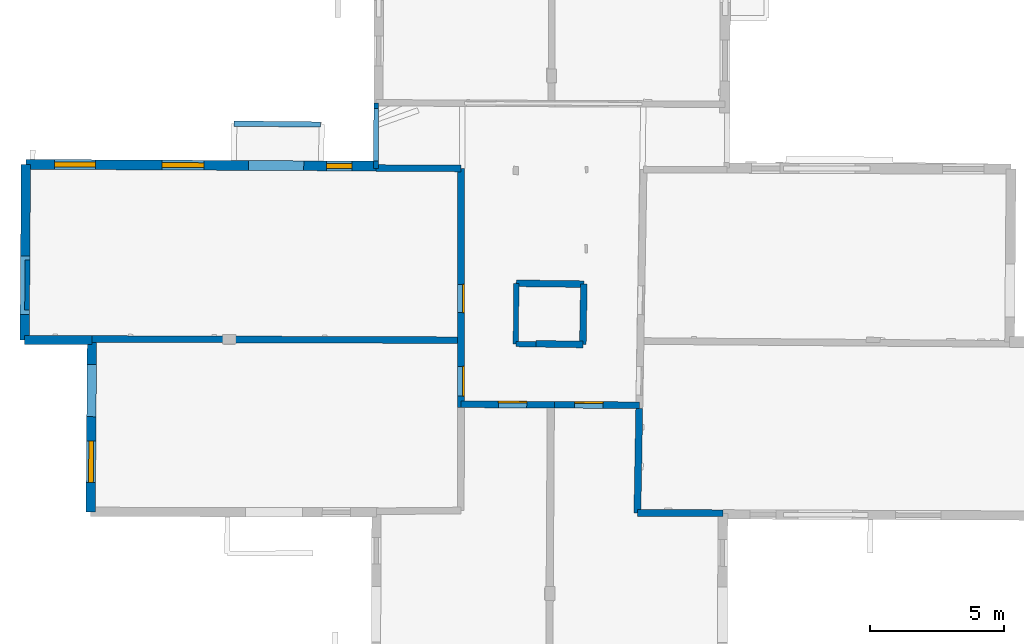
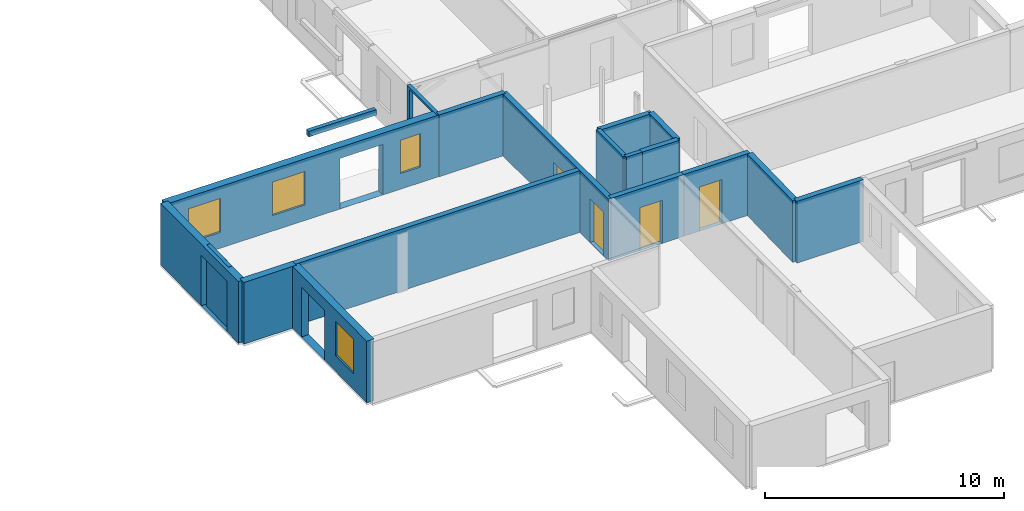
# One storey, part 3 of 14: 19 walls, 4 doors, 4 windows, 12 openings.
"""IFC2X3 building model written with IfcOpenShell, lengths in metres."""

from ifc_helpers import new_model, entity, si_unit, converted_unit, derived_unit, direction, frame, frame_2d, origin, origin_2d_with_axis, place, context, subcontext, project, spatial, polyline, rectangle, outline, extrude, source, transform, mapped, material, layer, layer_set, layer_usage, type_object, type_shapes, element, fill, save


model = new_model("IFC2X3")

# Units and contexts
model_context = context("Model", 3, precision=1e-05, world=origin(), true_north=direction((0.0, 1.0)))
body_context = subcontext(model_context, "Body", "Model", "MODEL_VIEW")
ifc_project = project(units=[si_unit("LENGTHUNIT", "METRE"), si_unit("AREAUNIT", "SQUARE_METRE"), si_unit("VOLUMEUNIT", "CUBIC_METRE"), converted_unit("PLANEANGLEUNIT", "DEGREE", entity("IfcRatioMeasure", 0.0174532925199433), si_unit("PLANEANGLEUNIT", "RADIAN"), dimensions=[0, 0, 0, 0, 0, 0, 0]), si_unit("MASSUNIT", "GRAM", prefix="KILO"), derived_unit("MASSDENSITYUNIT", [(si_unit("MASSUNIT", "GRAM", prefix="KILO"), 1), (si_unit("LENGTHUNIT", "METRE"), -3)]), derived_unit("MOMENTOFINERTIAUNIT", [(si_unit("LENGTHUNIT", "METRE"), 4)]), si_unit("TIMEUNIT", "SECOND"), si_unit("FREQUENCYUNIT", "HERTZ"), si_unit("THERMODYNAMICTEMPERATUREUNIT", "DEGREE_CELSIUS"), derived_unit("THERMALTRANSMITTANCEUNIT", [(si_unit("MASSUNIT", "GRAM", prefix="KILO"), 1), (si_unit("THERMODYNAMICTEMPERATUREUNIT", "KELVIN"), -1), (si_unit("TIMEUNIT", "SECOND"), -3)]), derived_unit("VOLUMETRICFLOWRATEUNIT", [(si_unit("LENGTHUNIT", "METRE"), 3), (si_unit("TIMEUNIT", "SECOND"), -1)]), si_unit("ELECTRICCURRENTUNIT", "AMPERE"), si_unit("ELECTRICVOLTAGEUNIT", "VOLT"), si_unit("POWERUNIT", "WATT"), si_unit("FORCEUNIT", "NEWTON", prefix="KILO"), si_unit("ILLUMINANCEUNIT", "LUX"), si_unit("LUMINOUSFLUXUNIT", "LUMEN"), si_unit("LUMINOUSINTENSITYUNIT", "CANDELA"), derived_unit("USERDEFINED", [(si_unit("MASSUNIT", "GRAM", prefix="KILO"), -1), (si_unit("LENGTHUNIT", "METRE"), -2), (si_unit("TIMEUNIT", "SECOND"), 3), (si_unit("LUMINOUSFLUXUNIT", "LUMEN"), 1)]), derived_unit("LINEARVELOCITYUNIT", [(si_unit("LENGTHUNIT", "METRE"), 1), (si_unit("TIMEUNIT", "SECOND"), -1)]), si_unit("PRESSUREUNIT", "PASCAL"), derived_unit("USERDEFINED", [(si_unit("LENGTHUNIT", "METRE"), -2), (si_unit("MASSUNIT", "GRAM", prefix="KILO"), 1), (si_unit("TIMEUNIT", "SECOND"), -2)]), derived_unit("LINEARFORCEUNIT", [(si_unit("MASSUNIT", "GRAM", prefix="KILO"), 1), (si_unit("LENGTHUNIT", "METRE"), 1), (si_unit("TIMEUNIT", "SECOND"), -2), (si_unit("LENGTHUNIT", "METRE"), -1)]), derived_unit("PLANARFORCEUNIT", [(si_unit("MASSUNIT", "GRAM", prefix="KILO"), 1), (si_unit("LENGTHUNIT", "METRE"), 1), (si_unit("TIMEUNIT", "SECOND"), -2), (si_unit("LENGTHUNIT", "METRE"), -2)])], contexts=[model_context])

# Site, building, storey
placement_1 = place(None, origin())
site = spatial("IfcSite", under=ifc_project, at=placement_1, CompositionType="ELEMENT")
building = spatial("IfcBuilding", under=site, at=placement_1, CompositionType="ELEMENT")
storey_placement = place(placement_1, frame((0.0, 0.0, 8.83152770996094)))
storey = spatial("IfcBuildingStorey", under=building, at=storey_placement, Name="Level 4", CompositionType="ELEMENT", Elevation=8.83152770996094)

# Wall
ifc_material_1 = material(Name="Default wall")
ifc_layer_1 = layer(ifc_material_1, 0.25)
ifc_layer_set_1 = layer_set([ifc_layer_1], Name="wall_thickness_0.2500")
ifc_layer_usage_1 = layer_usage(ifc_layer_set_1, "AXIS2", "POSITIVE", -0.125)
wall_type_1 = type_object("IfcWallType", Name="wall_thickness_0.2500", PredefinedType="STANDARD", material=ifc_layer_set_1)
wall_1_placement = place(storey_placement, frame((4.90263241764473, 21.567697794984, 0.0), z_axis=(0.0, 0.0, 1.0), x_axis=(0.999921550442488, -0.0125256920244768, 0.0)))
element("IfcWallStandardCase", 1, at=wall_1_placement, inside=storey, type_object=wall_type_1, material=ifc_layer_usage_1, Name="Wall:382", ObjectType="Wall", context=body_context, shape_type="SweptSolid", body=[
    extrude(outline(polyline([(2.53233176272325, -0.125), (2.53233176272325, 0.125), (0.0, 0.125), (0.0, -0.125), (2.53233176272325, -0.125)])), origin(), (0.0, 0.0, 1.0), 3.14668312072754),
])

# Wall, openings, doors
wall_2_placement = place(storey_placement, frame((2.83575512035134, 25.8687037352713, 0.0), z_axis=(0.0, 0.0, 1.0), x_axis=(-0.000411126826557853, -0.999999915487363, 0.0)))
wall_2 = element("IfcWallStandardCase", 2, at=wall_2_placement, inside=storey, type_object=wall_type_1, material=ifc_layer_usage_1, Name="Wall:383", ObjectType="Wall", context=body_context, shape_type="SweptSolid", body=[
    extrude(outline(polyline([(8.95736579302135, -0.125), (8.95736579302135, 0.125), (0.0, 0.125), (0.0, -0.125), (8.95736579302135, -0.125)])), origin(), (0.0, 0.0, 1.0), 3.14668312072754),
])
opening_1_placement = place(wall_2_placement, frame((4.34125555554509, -0.125, 0.00547218322753906)))
opening_1 = element("IfcOpeningElement", 3, at=opening_1_placement, cuts=wall_2, Name="Opening : 1055 x 2235 : 304", ObjectType="Opening", context=body_context, shape_type="SweptSolid", body=[
    extrude(rectangle(XDim=1.055, YDim=2.235, at=frame_2d((1.1175, 0.5275), x_axis=(0.0, 1.0))), frame((0.0, 0.0, 0.0), z_axis=(0.0, 1.0, 0.0), x_axis=(0.0, 0.0, 1.0)), (0.0, 0.0, 1.0), 0.25),
])
opening_2_placement = place(wall_2_placement, frame((7.41011682260127, -0.125, 0.00647258758544922)))
opening_2 = element("IfcOpeningElement", 4, at=opening_2_placement, cuts=wall_2, Name="Opening : 1120 x 2235 : 305", ObjectType="Opening", context=body_context, shape_type="SweptSolid", body=[
    extrude(rectangle(XDim=1.12, YDim=2.235, at=frame_2d((1.1175, 0.56), x_axis=(0.0, 1.0))), frame((0.0, 0.0, 0.0), z_axis=(0.0, 1.0, 0.0), x_axis=(0.0, 0.0, 1.0)), (0.0, 0.0, 1.0), 0.25),
])
ifc_material_2 = material(Name="Door Panel")
door_style_1 = type_object("IfcDoorStyle", Name="Door : 1055 x 2235mm", ConstructionType="NOTDEFINED", OperationType="SINGLE_SWING_RIGHT", ParameterTakesPrecedence=False, Sizeable=False, material=ifc_material_2)
shared_shape_1 = source(origin(), body_context, "Body", "SweptSolid", [
    extrude(rectangle(XDim=0.0625, YDim=1.055, at=origin_2d_with_axis()), frame((0.5275, 0.21875, 0.0), z_axis=(0.0, 0.0, 1.0), x_axis=(0.0, 1.0, 0.0)), (0.0, 0.0, 1.0), 2.235),
])
type_shapes(door_style_1, [shared_shape_1])
door_1_placement = place(opening_1_placement, origin())
door_1 = element("IfcDoor", 5, at=door_1_placement, inside=storey, type_object=door_style_1, Name="Door : 1055 x 2235mm : 57", ObjectType="Door : 1055 x 2235mm", OverallHeight=2.235, OverallWidth=1.055, context=body_context, shape_type="MappedRepresentation", body=[
    mapped(shared_shape_1, transform((0.0, 0.0, 0.0), scale=1.0)),
])
fill(opening_1, door_1)
door_style_2 = type_object("IfcDoorStyle", Name="Door : 1120 x 2235mm", ConstructionType="NOTDEFINED", OperationType="SINGLE_SWING_RIGHT", ParameterTakesPrecedence=False, Sizeable=False, material=ifc_material_2)
shared_shape_2 = source(origin(), body_context, "Body", "SweptSolid", [
    extrude(rectangle(XDim=0.0625, YDim=1.12, at=origin_2d_with_axis()), frame((0.56, 0.21875, 0.0), z_axis=(0.0, 0.0, 1.0), x_axis=(0.0, 1.0, 0.0)), (0.0, 0.0, 1.0), 2.235),
])
type_shapes(door_style_2, [shared_shape_2])
door_2_placement = place(opening_2_placement, origin())
door_2 = element("IfcDoor", 6, at=door_2_placement, inside=storey, type_object=door_style_2, Name="Door : 1120 x 2235mm : 58", ObjectType="Door : 1120 x 2235mm", OverallHeight=2.235, OverallWidth=1.12, context=body_context, shape_type="MappedRepresentation", body=[
    mapped(shared_shape_2, transform((0.0, 0.0, 0.0), scale=1.0)),
])
fill(opening_2, door_2)

# Wall
wall_3_placement = place(storey_placement, frame((-10.9847354461438, 19.4825045448759, 0.0), z_axis=(0.0, 0.0, 1.0), x_axis=(0.999994767675182, -0.00323490683920543, 0.0)))
element("IfcWallStandardCase", 7, at=wall_3_placement, inside=storey, type_object=wall_type_1, material=ifc_layer_usage_1, Name="Wall:387", ObjectType="Wall", context=body_context, shape_type="SweptSolid", body=[
    extrude(outline(polyline([(13.880709320427, -0.125), (13.880709320427, 0.125), (0.0, 0.125), (0.0, -0.125), (13.880709320427, -0.125)])), origin(), (0.0, 0.0, 1.0), 3.14668312072754),
])

# Wall, opening, door
wall_4_placement = place(storey_placement, frame((2.83212357896724, 17.036337199446, 0.0), z_axis=(0.0, 0.0, 1.0), x_axis=(0.999987146241394, -0.00507024180818238, 0.0)))
wall_4 = element("IfcWallStandardCase", 8, at=wall_4_placement, inside=storey, type_object=wall_type_1, material=ifc_layer_usage_1, Name="Wall:423", ObjectType="Wall", context=body_context, shape_type="SweptSolid", body=[
    extrude(outline(polyline([(3.50002472289368, -0.125), (3.50002472289368, 0.125), (0.0, 0.125), (0.0, -0.125), (3.50002472289368, -0.125)])), origin(), (0.0, 0.0, 1.0), 3.14668312072754),
])
opening_3_placement = place(wall_4_placement, frame((1.39978372506363, -0.125, 0.00647258758544922)))
opening_3 = element("IfcOpeningElement", 9, at=opening_3_placement, cuts=wall_4, Name="Opening : 1065 x 2190 : 330", ObjectType="Opening", context=body_context, shape_type="SweptSolid", body=[
    extrude(rectangle(XDim=1.065, YDim=2.19, at=frame_2d((1.095, 0.5325), x_axis=(0.0, 1.0))), frame((0.0, 0.0, 0.0), z_axis=(0.0, 1.0, 0.0), x_axis=(0.0, 0.0, 1.0)), (0.0, 0.0, 1.0), 0.25),
])
door_style_3 = type_object("IfcDoorStyle", Name="Door : 1065 x 2190mm", ConstructionType="NOTDEFINED", OperationType="SINGLE_SWING_RIGHT", ParameterTakesPrecedence=False, Sizeable=False, material=ifc_material_2)
shared_shape_3 = source(origin(), body_context, "Body", "SweptSolid", [
    extrude(rectangle(XDim=0.0625, YDim=1.065, at=origin_2d_with_axis()), frame((0.5325, 0.21875, 0.0), z_axis=(0.0, 0.0, 1.0), x_axis=(0.0, 1.0, 0.0)), (0.0, 0.0, 1.0), 2.19),
])
type_shapes(door_style_3, [shared_shape_3])
door_3_placement = place(opening_3_placement, origin())
door_3 = element("IfcDoor", 10, at=door_3_placement, inside=storey, type_object=door_style_3, Name="Door : 1065 x 2190mm : 61", ObjectType="Door : 1065 x 2190mm", OverallHeight=2.19, OverallWidth=1.065, context=body_context, shape_type="MappedRepresentation", body=[
    mapped(shared_shape_3, transform((0.0, 0.0, 0.0), scale=1.0)),
])
fill(opening_3, door_3)

wall_5_placement = place(storey_placement, frame((6.33210331338802, 17.0185912277663, 0.0), z_axis=(0.0, 0.0, 1.0), x_axis=(0.999987148651248, -0.00506976649826233, 0.0)))
wall_5 = element("IfcWallStandardCase", 11, at=wall_5_placement, inside=storey, type_object=wall_type_1, material=ifc_layer_usage_1, Name="Wall:424", ObjectType="Wall", context=body_context, shape_type="SweptSolid", body=[
    extrude(outline(polyline([(3.1798132419031, -0.125), (3.1798132419031, 0.125), (0.0, 0.125), (0.0, -0.125), (3.1798132419031, -0.125)])), origin(), (0.0, 0.0, 1.0), 3.14668312072754),
])
opening_4_placement = place(wall_5_placement, frame((0.759759601834799, -0.125, 0.00647258758544922)))
opening_4 = element("IfcOpeningElement", 12, at=opening_4_placement, cuts=wall_5, Name="Opening : 1065 x 2250 : 331", ObjectType="Opening", context=body_context, shape_type="SweptSolid", body=[
    extrude(rectangle(XDim=1.065, YDim=2.25, at=frame_2d((1.125, 0.5325), x_axis=(0.0, 1.0))), frame((0.0, 0.0, 0.0), z_axis=(0.0, 1.0, 0.0), x_axis=(0.0, 0.0, 1.0)), (0.0, 0.0, 1.0), 0.25),
])
door_style_4 = type_object("IfcDoorStyle", Name="Door : 1065 x 2250mm", ConstructionType="NOTDEFINED", OperationType="SINGLE_SWING_RIGHT", ParameterTakesPrecedence=False, Sizeable=False, material=ifc_material_2)
shared_shape_4 = source(origin(), body_context, "Body", "SweptSolid", [
    extrude(rectangle(XDim=0.0625, YDim=1.065, at=origin_2d_with_axis()), frame((0.5325, 0.21875, 0.0), z_axis=(0.0, 0.0, 1.0), x_axis=(0.0, 1.0, 0.0)), (0.0, 0.0, 1.0), 2.25),
])
type_shapes(door_style_4, [shared_shape_4])
door_4_placement = place(opening_4_placement, origin())
door_4 = element("IfcDoor", 13, at=door_4_placement, inside=storey, type_object=door_style_4, Name="Door : 1065 x 2250mm : 62", ObjectType="Door : 1065 x 2250mm", OverallHeight=2.25, OverallWidth=1.065, context=body_context, shape_type="MappedRepresentation", body=[
    mapped(shared_shape_4, transform((0.0, 0.0, 0.0), scale=1.0)),
])
fill(opening_4, door_4)

# Walls
wall_6_placement = place(storey_placement, frame((5.64531664419107, 19.303205070622, 0.0), z_axis=(0.0, 0.0, 1.0), x_axis=(0.999866020035043, -0.0163689333581485, 0.0)))
element("IfcWallStandardCase", 14, at=wall_6_placement, inside=storey, type_object=wall_type_1, material=ifc_layer_usage_1, Name="Wall:425", ObjectType="Wall", context=body_context, shape_type="SweptSolid", body=[
    extrude(outline(polyline([(1.75273107337098, -0.125), (1.75273107337098, 0.125), (0.0, 0.125), (0.0, -0.125), (1.75273107337098, -0.125)])), origin(), (0.0, 0.0, 1.0), 3.14668312072754),
])
wall_7_placement = place(storey_placement, frame((7.43476486762894, 21.5359807769144, 0.0), z_axis=(0.0, 0.0, 1.0), x_axis=(-0.0163378881642375, -0.999866527797752, 0.0)))
element("IfcWallStandardCase", 15, at=wall_7_placement, inside=storey, type_object=wall_type_1, material=ifc_layer_usage_1, Name="Wall:435", ObjectType="Wall", context=body_context, shape_type="SweptSolid", body=[
    extrude(outline(polyline([(2.26176695564838, -0.125), (2.26176695564838, 0.125), (0.0, 0.125), (0.0, -0.125), (2.26176695564838, -0.125)])), origin(), (0.0, 0.0, 1.0), 3.14668312072754),
])
wall_8_placement = place(storey_placement, frame((-0.347936725044121, 25.8836817273371, 0.0), z_axis=(0.0, 0.0, 1.0), x_axis=(0.999988930127148, -0.00470527609843498, 0.0)))
element("IfcWallStandardCase", 16, at=wall_8_placement, inside=storey, type_object=wall_type_1, material=ifc_layer_usage_1, Name="Wall:476", ObjectType="Wall", context=body_context, shape_type="SweptSolid", body=[
    extrude(outline(polyline([(3.18372734112074, -0.125), (3.18372734112074, 0.125), (0.0, 0.125), (0.0, -0.125), (3.18372734112074, -0.125)])), origin(), (0.0, 0.0, 1.0), 3.14668312072754),
])

# Wall, openings, window
ifc_layer_2 = layer(ifc_material_1, 0.349999994039536)
ifc_layer_set_2 = layer_set([ifc_layer_2], Name="wall_thickness_0.3500")
ifc_layer_usage_2 = layer_usage(ifc_layer_set_2, "AXIS2", "POSITIVE", -0.174999997019768)
wall_type_2 = type_object("IfcWallType", Name="wall_thickness_0.3500", PredefinedType="STANDARD", material=ifc_layer_set_2)
wall_9_placement = place(storey_placement, frame((-10.9847340181037, 19.4825032417059, 0.0), z_axis=(0.0, 0.0, 1.0), x_axis=(-0.00756765181459916, -0.999971364913022, 0.0)))
wall_9 = element("IfcWallStandardCase", 17, at=wall_9_placement, inside=storey, type_object=wall_type_2, material=ifc_layer_usage_2, Name="Wall:415", ObjectType="Wall", context=body_context, shape_type="SweptSolid", body=[
    extrude(outline(polyline([(6.47489968849056, -0.174999997019768), (6.47489968849056, 0.174999997019768), (0.0, 0.174999997019768), (0.0, -0.174999997019768), (6.47489968849056, -0.174999997019768)])), origin(), (0.0, 0.0, 1.0), 3.14668312072754),
])
opening_5_placement = place(wall_9_placement, frame((0.952328285413217, -0.174999997019768, 0.00547218322753906)))
element("IfcOpeningElement", 18, at=opening_5_placement, cuts=wall_9, Name="Opening : 1960 x 2540 : 328", ObjectType="Opening", context=body_context, shape_type="SweptSolid", body=[
    extrude(rectangle(XDim=1.96, YDim=2.54, at=frame_2d((1.27, 0.98), x_axis=(0.0, 1.0))), frame((0.0, 0.0, 0.0), z_axis=(0.0, 1.0, 0.0), x_axis=(0.0, 0.0, 1.0)), (0.0, 0.0, 1.0), 0.349999994039536),
])
opening_6_placement = place(wall_9_placement, frame((3.82732764260143, -0.174999997019768, 0.800472259521484)))
opening_6 = element("IfcOpeningElement", 19, at=opening_6_placement, cuts=wall_9, Name="Opening : 1550 x 1760 : 329", ObjectType="Opening", context=body_context, shape_type="SweptSolid", body=[
    extrude(rectangle(XDim=1.55, YDim=1.76, at=frame_2d((0.88, 0.775), x_axis=(0.0, 1.0))), frame((0.0, 0.0, 0.0), z_axis=(0.0, 1.0, 0.0), x_axis=(0.0, 0.0, 1.0)), (0.0, 0.0, 1.0), 0.349999994039536),
])
ifc_material_3 = material(Name="Window Default")
window_style_1 = type_object("IfcWindowStyle", Name="Window : 1550 x 1760mm", ConstructionType="NOTDEFINED", OperationType="NOTDEFINED", ParameterTakesPrecedence=False, Sizeable=False, material=ifc_material_3)
shared_shape_5 = source(origin(), body_context, "Body", "SweptSolid", [
    extrude(rectangle(XDim=0.174999997019768, YDim=1.55, at=origin_2d_with_axis()), frame((0.775, 0.174999997019768, 0.0), z_axis=(0.0, 0.0, 1.0), x_axis=(0.0, 1.0, 0.0)), (0.0, 0.0, 1.0), 1.76),
])
type_shapes(window_style_1, [shared_shape_5])
window_1_placement = place(opening_6_placement, origin())
window_1 = element("IfcWindow", 20, at=window_1_placement, inside=storey, type_object=window_style_1, Name="Window : 1550 x 1760mm : 178", ObjectType="Window : 1550 x 1760mm", OverallHeight=1.76, OverallWidth=1.55, context=body_context, shape_type="MappedRepresentation", body=[
    mapped(shared_shape_5, transform((0.0, 0.0, 0.0), scale=1.0)),
])
fill(opening_6, window_1)

# Wall, opening
wall_10_placement = place(storey_placement, frame((-13.4592569428142, 26.0215091704078, 0.0), z_axis=(0.0, 0.0, 1.0), x_axis=(-0.00708465455772878, -0.999974903519982, 0.0)))
wall_10 = element("IfcWallStandardCase", 21, at=wall_10_placement, inside=storey, type_object=wall_type_2, material=ifc_layer_usage_2, Name="Wall:482", ObjectType="Wall", context=body_context, shape_type="SweptSolid", body=[
    extrude(outline(polyline([(6.57629876997802, -0.174999997019768), (6.57629876997802, 0.174999997019768), (0.0, 0.174999997019768), (0.0, -0.174999997019768), (6.57629876997802, -0.174999997019768)])), origin(), (0.0, 0.0, 1.0), 3.14668312072754),
])
opening_7_placement = place(wall_10_placement, frame((3.43399545653638, -0.174999997019768, 0.00547218322753906)))
element("IfcOpeningElement", 22, at=opening_7_placement, cuts=wall_10, Name="Opening : 2185 x 2570 : 376", ObjectType="Opening", context=body_context, shape_type="SweptSolid", body=[
    extrude(rectangle(XDim=2.185, YDim=2.57, at=frame_2d((1.285, 1.0925), x_axis=(0.0, 1.0))), frame((0.0, 0.0, 0.0), z_axis=(0.0, 1.0, 0.0), x_axis=(0.0, 0.0, 1.0)), (0.0, 0.0, 1.0), 0.349999994039536),
])

# Walls
ifc_layer_3 = layer(ifc_material_1, 0.2)
ifc_layer_set_3 = layer_set([ifc_layer_3], Name="wall_thickness_0.2000")
ifc_layer_usage_3 = layer_usage(ifc_layer_set_3, "AXIS2", "POSITIVE", -0.1)
wall_type_3 = type_object("IfcWallType", Name="wall_thickness_0.2000", PredefinedType="STANDARD", material=ifc_layer_set_3)
wall_11_placement = place(storey_placement, frame((4.90263258302256, 21.567696693767, 0.0), z_axis=(0.0, 0.0, 1.0), x_axis=(-0.00653155766500339, -0.999978669149732, 0.0)))
element("IfcWallStandardCase", 23, at=wall_11_placement, inside=storey, type_object=wall_type_3, material=ifc_layer_usage_3, Name="Wall:419", ObjectType="Wall", context=body_context, shape_type="SweptSolid", body=[
    extrude(outline(polyline([(2.2744015422625, -0.1), (2.2744015422625, 0.1), (0.0, 0.1), (0.0, -0.1), (2.2744015422625, -0.1)])), origin(), (0.0, 0.0, 1.0), 3.14668312072754),
])
wall_12_placement = place(storey_placement, frame((4.8877771475465, 19.2933474372307, 0.0), z_axis=(0.0, 0.0, 1.0), x_axis=(0.999861555918534, -0.0166393808829662, 0.0)))
element("IfcWallStandardCase", 24, at=wall_12_placement, inside=storey, type_object=wall_type_3, material=ifc_layer_usage_3, Name="Wall:430", ObjectType="Wall", context=body_context, shape_type="SweptSolid", body=[
    extrude(outline(polyline([(0.75723641143752, -0.1), (0.75723641143752, 0.1), (0.0, 0.1), (0.0, -0.1), (0.75723641143752, -0.1)])), origin(), (0.0, 0.0, 1.0), 3.14668312072754),
])
placement_2 = place(placement_1, frame((0.0, 0.0, 11.6920003890991)))
wall_13_placement = place(placement_2, frame((-5.66090134363591, 27.5473975539503, 0.0), z_axis=(0.0, 0.0, 1.0), x_axis=(0.999945999076033, -0.0103922534531535, 0.0)))
element("IfcWallStandardCase", 25, at=wall_13_placement, inside=storey, type_object=wall_type_3, material=ifc_layer_usage_3, Name="Wall:469", ObjectType="Wall", context=body_context, shape_type="SweptSolid", body=[
    extrude(outline(polyline([(3.23848593355505, -0.1), (3.23848593355505, 0.1), (0.0, 0.1), (0.0, -0.1), (3.23848593355505, -0.1)])), origin(), (0.0, 0.0, 1.0), 0.286210441589356),
])
ifc_layer_4 = layer(ifc_material_1, 0.259999990463257)
ifc_layer_set_4 = layer_set([ifc_layer_4], Name="wall_thickness_0.2600")
ifc_layer_usage_4 = layer_usage(ifc_layer_set_4, "AXIS2", "POSITIVE", -0.129999995231628)
wall_type_4 = type_object("IfcWallType", Name="wall_thickness_0.2600", PredefinedType="STANDARD", material=ifc_layer_set_4)
wall_14_placement = place(storey_placement, frame((9.44029684000763, 12.9689048306405, 0.0), z_axis=(0.0, 0.0, 1.0), x_axis=(0.999991001393006, -0.0042423027959179, 0.0)))
element("IfcWallStandardCase", 26, at=wall_14_placement, inside=storey, type_object=wall_type_4, material=ifc_layer_usage_4, Name="Wall:466", ObjectType="Wall", context=body_context, shape_type="SweptSolid", body=[
    extrude(outline(polyline([(3.19981879482731, -0.129999995231628), (3.19981879482731, 0.129999995231628), (0.0, 0.129999995231628), (0.0, -0.129999995231628), (3.19981879482731, -0.129999995231628)])), origin(), (0.0, 0.0, 1.0), 3.14668312072754),
])
wall_15_placement = place(storey_placement, frame((9.50965730417198, 16.8774999816989, 0.0), z_axis=(0.0, 0.0, 1.0), x_axis=(-0.0177426438266491, -0.999842586905579, 0.0)))
element("IfcWallStandardCase", 27, at=wall_15_placement, inside=storey, type_object=wall_type_4, material=ifc_layer_usage_4, Name="Wall:479", ObjectType="Wall", context=body_context, shape_type="SweptSolid", body=[
    extrude(outline(polyline([(3.90921330753048, -0.129999995231628), (3.90921330753048, 0.129999995231628), (0.0, 0.129999995231628), (0.0, -0.129999995231628), (3.90921330753048, -0.129999995231628)])), origin(), (0.0, 0.0, 1.0), 3.14668312072754),
])
ifc_layer_5 = layer(ifc_material_1, 0.340000003576279)
ifc_layer_set_5 = layer_set([ifc_layer_5], Name="wall_thickness_0.3400")
ifc_layer_usage_5 = layer_usage(ifc_layer_set_5, "AXIS2", "POSITIVE", -0.170000001788139)
wall_type_5 = type_object("IfcWallType", Name="wall_thickness_0.3400", PredefinedType="STANDARD", material=ifc_layer_set_5)
wall_16_placement = place(storey_placement, frame((-13.5058482540374, 19.4453753250842, 0.0), z_axis=(0.0, 0.0, 1.0), x_axis=(0.999999748144102, -0.000709726519724362, 0.0)))
element("IfcWallStandardCase", 28, at=wall_16_placement, inside=storey, type_object=wall_type_5, material=ifc_layer_usage_5, Name="Wall:392", ObjectType="Wall", context=body_context, shape_type="SweptSolid", body=[
    extrude(outline(polyline([(2.52082029888493, -0.170000001788139), (2.52082029888493, 0.170000001788139), (0.0, 0.170000001788139), (0.0, -0.170000001788139), (2.52082029888493, -0.170000001788139)])), origin(), (0.0, 0.0, 1.0), 3.14668312072754),
])

# Wall, openings, windows
ifc_layer_6 = layer(ifc_material_1, 0.370000004768372)
ifc_layer_set_6 = layer_set([ifc_layer_6], Name="wall_thickness_0.3700")
ifc_layer_usage_6 = layer_usage(ifc_layer_set_6, "AXIS2", "POSITIVE", -0.185000002384186)
wall_type_6 = type_object("IfcWallType", Name="wall_thickness_0.3700", PredefinedType="STANDARD", material=ifc_layer_set_6)
wall_17_placement = place(storey_placement, frame((-13.4592588588332, 26.0215071028375, 0.0), z_axis=(0.0, 0.0, 1.0), x_axis=(0.999987656159895, -0.0049686545300924, 0.0)))
wall_17 = element("IfcWallStandardCase", 29, at=wall_17_placement, inside=storey, type_object=wall_type_6, material=ifc_layer_usage_6, Name="Wall:436", ObjectType="Wall", context=body_context, shape_type="SweptSolid", body=[
    extrude(outline(polyline([(13.1116783241382, -0.185000002384186), (13.1116783241382, 0.185000002384186), (0.0, 0.185000002384186), (0.0, -0.185000002384186), (13.1116783241382, -0.185000002384186)])), origin(), (0.0, 0.0, 1.0), 3.14668312072754),
])
opening_8_placement = place(wall_17_placement, frame((8.33982554260816, -0.185000002384186, 0.00547218322753906)))
element("IfcOpeningElement", 30, at=opening_8_placement, cuts=wall_17, Name="Opening : 2065 x 2570 : 336", ObjectType="Opening", context=body_context, shape_type="SweptSolid", body=[
    extrude(rectangle(XDim=2.065, YDim=2.57, at=frame_2d((1.285, 1.0325), x_axis=(0.0, 1.0))), frame((0.0, 0.0, 0.0), z_axis=(0.0, 1.0, 0.0), x_axis=(0.0, 0.0, 1.0)), (0.0, 0.0, 1.0), 0.370000004768372),
])
opening_9_placement = place(wall_17_placement, frame((1.0648267161735, -0.185000002384186, 0.805472373962402)))
opening_9 = element("IfcOpeningElement", 31, at=opening_9_placement, cuts=wall_17, Name="Opening : 1545 x 1735 : 337", ObjectType="Opening", context=body_context, shape_type="SweptSolid", body=[
    extrude(rectangle(XDim=1.545, YDim=1.735, at=frame_2d((0.8675, 0.7725), x_axis=(0.0, 1.0))), frame((0.0, 0.0, 0.0), z_axis=(0.0, 1.0, 0.0), x_axis=(0.0, 0.0, 1.0)), (0.0, 0.0, 1.0), 0.370000004768372),
])
opening_10_placement = place(wall_17_placement, frame((5.09982774116884, -0.185000002384186, 0.790472030639648)))
opening_10 = element("IfcOpeningElement", 32, at=opening_10_placement, cuts=wall_17, Name="Opening : 1565 x 1710 : 338", ObjectType="Opening", context=body_context, shape_type="SweptSolid", body=[
    extrude(rectangle(XDim=1.565, YDim=1.71, at=frame_2d((0.855, 0.7825), x_axis=(0.0, 1.0))), frame((0.0, 0.0, 0.0), z_axis=(0.0, 1.0, 0.0), x_axis=(0.0, 0.0, 1.0)), (0.0, 0.0, 1.0), 0.370000004768372),
])
opening_11_placement = place(wall_17_placement, frame((11.2498269824025, -0.185000002384186, 0.795472145080566)))
opening_11 = element("IfcOpeningElement", 33, at=opening_11_placement, cuts=wall_17, Name="Opening : 970 x 1705 : 339", ObjectType="Opening", context=body_context, shape_type="SweptSolid", body=[
    extrude(rectangle(XDim=0.97, YDim=1.705, at=frame_2d((0.8525, 0.485), x_axis=(0.0, 1.0))), frame((0.0, 0.0, 0.0), z_axis=(0.0, 1.0, 0.0), x_axis=(0.0, 0.0, 1.0)), (0.0, 0.0, 1.0), 0.370000004768372),
])
window_style_2 = type_object("IfcWindowStyle", Name="Window : 1565 x 1710mm", ConstructionType="NOTDEFINED", OperationType="NOTDEFINED", ParameterTakesPrecedence=False, Sizeable=False, material=ifc_material_3)
shared_shape_6 = source(origin(), body_context, "Body", "SweptSolid", [
    extrude(rectangle(XDim=0.185000002384186, YDim=1.565, at=origin_2d_with_axis()), frame((0.7825, 0.185000002384186, 0.0), z_axis=(0.0, 0.0, 1.0), x_axis=(0.0, 1.0, 0.0)), (0.0, 0.0, 1.0), 1.71),
])
type_shapes(window_style_2, [shared_shape_6])
window_2_placement = place(opening_10_placement, origin())
window_2 = element("IfcWindow", 34, at=window_2_placement, inside=storey, type_object=window_style_2, Name="Window : 1565 x 1710mm : 181", ObjectType="Window : 1565 x 1710mm", OverallHeight=1.71, OverallWidth=1.565, context=body_context, shape_type="MappedRepresentation", body=[
    mapped(shared_shape_6, transform((0.0, 0.0, 0.0), scale=1.0)),
])
fill(opening_10, window_2)
window_style_3 = type_object("IfcWindowStyle", Name="Window : 1545 x 1735mm", ConstructionType="NOTDEFINED", OperationType="NOTDEFINED", ParameterTakesPrecedence=False, Sizeable=False, material=ifc_material_3)
shared_shape_7 = source(origin(), body_context, "Body", "SweptSolid", [
    extrude(rectangle(XDim=0.185000002384186, YDim=1.545, at=origin_2d_with_axis()), frame((0.7725, 0.185000002384186, 0.0), z_axis=(0.0, 0.0, 1.0), x_axis=(0.0, 1.0, 0.0)), (0.0, 0.0, 1.0), 1.735),
])
type_shapes(window_style_3, [shared_shape_7])
window_3_placement = place(opening_9_placement, origin())
window_3 = element("IfcWindow", 35, at=window_3_placement, inside=storey, type_object=window_style_3, Name="Window : 1545 x 1735mm : 180", ObjectType="Window : 1545 x 1735mm", OverallHeight=1.735, OverallWidth=1.545, context=body_context, shape_type="MappedRepresentation", body=[
    mapped(shared_shape_7, transform((0.0, 0.0, 0.0), scale=1.0)),
])
fill(opening_9, window_3)
window_style_4 = type_object("IfcWindowStyle", Name="Window : 970 x 1705mm", ConstructionType="NOTDEFINED", OperationType="NOTDEFINED", ParameterTakesPrecedence=False, Sizeable=False, material=ifc_material_3)
shared_shape_8 = source(origin(), body_context, "Body", "SweptSolid", [
    extrude(rectangle(XDim=0.185000002384186, YDim=0.97, at=origin_2d_with_axis()), frame((0.485, 0.185000002384186, 0.0), z_axis=(0.0, 0.0, 1.0), x_axis=(0.0, 1.0, 0.0)), (0.0, 0.0, 1.0), 1.705),
])
type_shapes(window_style_4, [shared_shape_8])
window_4_placement = place(opening_11_placement, origin())
window_4 = element("IfcWindow", 36, at=window_4_placement, inside=storey, type_object=window_style_4, Name="Window : 970 x 1705mm : 182", ObjectType="Window : 970 x 1705mm", OverallHeight=1.705, OverallWidth=0.97, context=body_context, shape_type="MappedRepresentation", body=[
    mapped(shared_shape_8, transform((0.0, 0.0, 0.0), scale=1.0)),
])
fill(opening_11, window_4)

# Wall
ifc_layer_7 = layer(ifc_material_1, 0.180000007152557)
ifc_layer_set_7 = layer_set([ifc_layer_7], Name="wall_thickness_0.1800")
ifc_layer_usage_7 = layer_usage(ifc_layer_set_7, "AXIS2", "POSITIVE", -0.0900000035762787)
wall_type_7 = type_object("IfcWallType", Name="wall_thickness_0.1800", PredefinedType="STANDARD", material=ifc_layer_set_7)
wall_18_placement = place(storey_placement, frame((-13.394961881958, 22.4324621719159, 0.0), z_axis=(0.0, 0.0, 1.0), x_axis=(-0.0116404595820113, -0.999932247555163, 0.0)))
element("IfcWallStandardCase", 37, at=wall_18_placement, inside=storey, type_object=wall_type_7, material=ifc_layer_usage_7, Name="Wall:377", ObjectType="Wall", context=body_context, shape_type="SweptSolid", body=[
    extrude(outline(polyline([(1.8653264231502, -0.0900000035762787), (1.8653264231502, 0.0900000035762787), (0.0, 0.0900000035762787), (0.0, -0.0900000035762787), (1.8653264231502, -0.0900000035762787)])), origin(), (0.0, 0.0, 1.0), 3.14668312072754),
])

# Wall, opening
wall_19_placement = place(storey_placement, frame((-0.341474966939298, 28.3271584081276, 0.0), z_axis=(0.0, 0.0, 1.0), x_axis=(-0.0026442804840884, -0.999996503884249, 0.0)))
wall_19 = element("IfcWallStandardCase", 38, at=wall_19_placement, inside=storey, type_object=wall_type_7, material=ifc_layer_usage_7, Name="Wall:391", ObjectType="Wall", context=body_context, shape_type="SweptSolid", body=[
    extrude(outline(polyline([(2.46514800748086, -0.0900000035762787), (2.46514800748086, 0.0900000035762787), (0.0, 0.0900000035762787), (0.0, -0.0900000035762787), (2.46514800748086, -0.0900000035762787)])), origin(), (0.0, 0.0, 1.0), 3.14668312072754),
])
opening_12_placement = place(wall_19_placement, frame((0.218834688999701, -0.0900000035762787, 0.00547218322753906)))
element("IfcOpeningElement", 39, at=opening_12_placement, cuts=wall_19, Name="Opening : 1955 x 3030 : 317", ObjectType="Opening", context=body_context, shape_type="SweptSolid", body=[
    extrude(rectangle(XDim=1.955, YDim=3.03, at=frame_2d((1.515, 0.9775), x_axis=(0.0, 1.0))), frame((0.0, 0.0, 0.0), z_axis=(0.0, 1.0, 0.0), x_axis=(0.0, 0.0, 1.0)), (0.0, 0.0, 1.0), 0.180000007152557),
])

save(model, "model.ifc")
